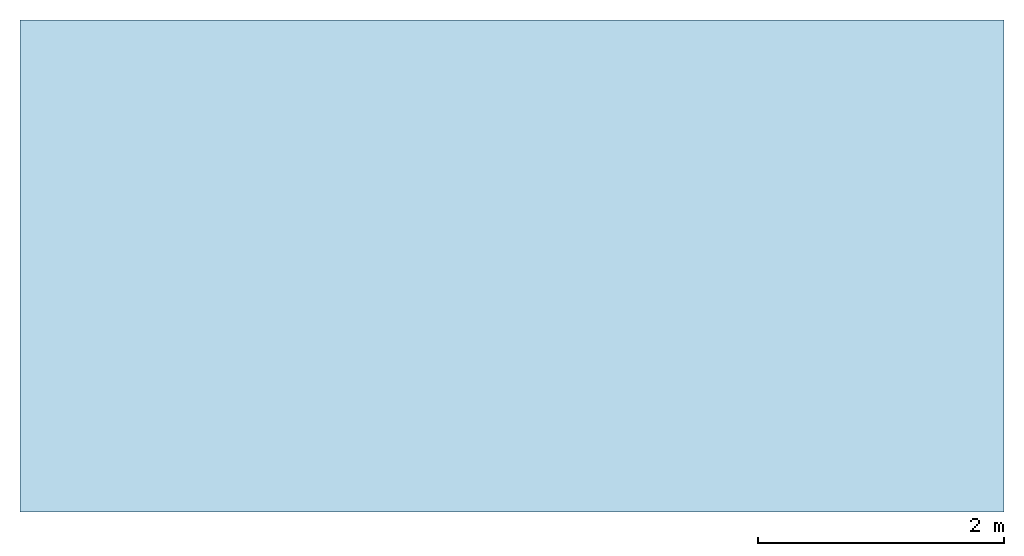
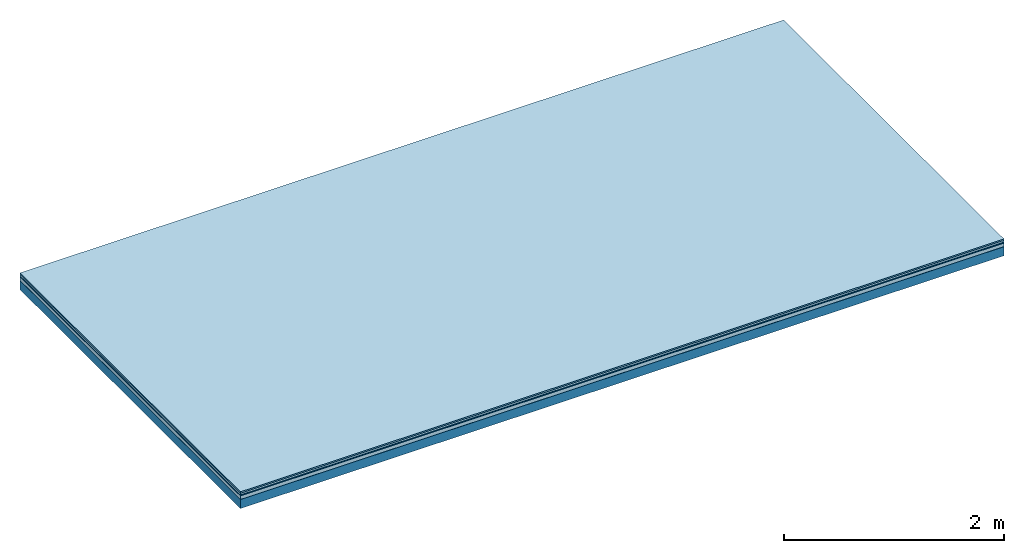
# One storey: 5 plates, 1 member, 1 element without a shape of its own.
"""IFC4 building model written with IfcOpenShell, lengths in metres."""

import ifcopenshell
import ifcopenshell.guid

model = None  # the IFC model being written
_history = None  # IfcOwnerHistory: only IFC2X3 demands one
_inside = {}  # id of a spatial element -> (the spatial element, [elements in it])
_under = {}  # id of a project, library or spatial element -> (it, [spatial elements below it])
_declared = {}  # id of a project -> (the project, [libraries it declares])
_typed = {}  # id of a type object -> (the type object, [elements of that type])
_made_of = {}  # id of a material, layer set ... -> (it, [elements and type objects made of it])


def new_model(schema):
    """Start an empty IFC model of exactly this schema.

    Asked for "IFC4X3", IfcOpenShell would pick the latest addendum, in which some entities
    have other attributes; the version numbers below select the first issue.
    IFC2X3 requires an IfcOwnerHistory on every rooted entity: one is made here for all.
    """
    global model, _history
    if schema == "IFC4X3":
        model = ifcopenshell.file(schema_version=(4, 3, 0, 0))
    else:
        model = ifcopenshell.file(schema=schema)
    _inside.clear()
    _under.clear()
    _declared.clear()
    _typed.clear()
    _made_of.clear()
    _history = None
    if model.schema == "IFC2X3":
        org = make("IfcOrganization", Name="unknown")
        user = make(
            "IfcPersonAndOrganization",
            ThePerson=make("IfcPerson", FamilyName="unknown"),
            TheOrganization=org,
        )
        app = make(
            "IfcApplication",
            ApplicationDeveloper=org,
            Version="unknown",
            ApplicationFullName="unknown",
            ApplicationIdentifier="unknown",
        )
        _history = make(
            "IfcOwnerHistory",
            OwningUser=user,
            OwningApplication=app,
            ChangeAction="ADDED",
            CreationDate=0,
        )
    return model


def make(cls, **values):
    """One entity of the class cls with the attributes given. An attribute that is None is left unset."""
    return model.create_entity(
        cls, **{name: value for name, value in values.items() if value is not None}
    )


def rooted(cls, **values):
    """An entity with a GlobalId (a new one), such as an element, a storey or a relation."""
    return make(cls, GlobalId=ifcopenshell.guid.new(), OwnerHistory=_history, **values)


def si_unit(unit_type, name, prefix=None):
    """IfcSIUnit, for example si_unit("LENGTHUNIT", "METRE", prefix="MILLI")."""
    return make("IfcSIUnit", UnitType=unit_type, Prefix=prefix, Name=name)


def derived_unit(unit_type, elements):
    """IfcDerivedUnit: a product of units, each with its exponent."""
    return make(
        "IfcDerivedUnit",
        Elements=[
            make("IfcDerivedUnitElement", Unit=unit, Exponent=power)
            for unit, power in elements
        ],
        UnitType=unit_type,
    )


def assignment(units):
    """IfcUnitAssignment: the units of a project."""
    return None if units is None else make("IfcUnitAssignment", Units=units)


def point(xyz):
    """IfcCartesianPoint."""
    return None if xyz is None else make("IfcCartesianPoint", Coordinates=xyz)


def direction(xyz):
    """IfcDirection."""
    return None if xyz is None else make("IfcDirection", DirectionRatios=xyz)


def frame(location, z_axis=None, x_axis=None):
    """IfcAxis2Placement3D, a coordinate frame: its origin and axes. An axis left out is left unset."""
    return make(
        "IfcAxis2Placement3D",
        Location=point(location),
        Axis=direction(z_axis),
        RefDirection=direction(x_axis),
    )


def frame_2d(location, x_axis=None):
    """IfcAxis2Placement2D, a coordinate frame in the plane: its origin and x axis."""
    return make(
        "IfcAxis2Placement2D", Location=point(location), RefDirection=direction(x_axis)
    )


def origin():
    """The frame at (0, 0, 0) with its axes left unset."""
    return frame((0.0, 0.0, 0.0))


def origin_with_axes():
    """The frame at (0, 0, 0) with the z axis (0, 0, 1) and the x axis (1, 0, 0) written out."""
    return frame((0.0, 0.0, 0.0), z_axis=(0.0, 0.0, 1.0), x_axis=(1.0, 0.0, 0.0))


def place(relative_to, where):
    """IfcLocalPlacement: puts the frame where relative to a parent placement (None: the world)."""
    return make(
        "IfcLocalPlacement", PlacementRelTo=relative_to, RelativePlacement=where
    )


def context(
    kind, dimensions, precision=None, world=None, true_north=None, identifier=None
):
    """IfcGeometricRepresentationContext, for example the 3D "Model" context."""
    return make(
        "IfcGeometricRepresentationContext",
        ContextIdentifier=identifier,
        ContextType=kind,
        CoordinateSpaceDimension=dimensions,
        Precision=precision,
        WorldCoordinateSystem=world,
        TrueNorth=true_north,
    )


def project(units=None, contexts=None):
    """IfcProject with its units and contexts."""
    return rooted(
        "IfcProject",
        Name="project",
        RepresentationContexts=contexts,
        UnitsInContext=assignment(units),
    )


def spatial(cls, under=None, at=None, **own):
    """A site, building, storey or space (cls), placed at a placement, below another one or the project."""
    s = rooted(cls, ObjectPlacement=at, **own)
    if under is not None:
        _under.setdefault(under.id(), (under, []))[1].append(s)
    return s


def profile(cls, at=None, kind="AREA", **sizes):
    """A parametric profile (cls). Its sizes go by their IFC names, for example OverallWidth=200.0."""
    return make(cls, ProfileType=kind, Position=at, **sizes)


def rectangle(**sizes):
    """IfcRectangleProfileDef."""
    return profile("IfcRectangleProfileDef", **sizes)


def extrude(swept, where, along, depth):
    """IfcExtrudedAreaSolid: the profile swept, set in the frame where, extruded along a direction by depth."""
    return make(
        "IfcExtrudedAreaSolid",
        SweptArea=swept,
        Position=where,
        ExtrudedDirection=direction(along),
        Depth=depth,
    )


def shape(context_of_items, identifier, shape_type, items):
    """IfcShapeRepresentation: the items that make up one representation, for example the "Body"."""
    return make(
        "IfcShapeRepresentation",
        ContextOfItems=context_of_items,
        RepresentationIdentifier=identifier,
        RepresentationType=shape_type,
        Items=items,
    )


def material(Name=None, Category=None):
    """IfcMaterial."""
    return make("IfcMaterial", Name=Name, Category=Category)


def layer(
    of_material, thickness, ventilated=None, Name=None, Category=None, Priority=None
):
    """IfcMaterialLayer: one layer of a wall or slab, of a material (None: an air gap)."""
    return make(
        "IfcMaterialLayer",
        Material=of_material,
        LayerThickness=thickness,
        IsVentilated=ventilated,
        Name=Name,
        Category=Category,
        Priority=Priority,
    )


def layer_set(layers, Name=None):
    """IfcMaterialLayerSet."""
    return make("IfcMaterialLayerSet", MaterialLayers=layers, LayerSetName=Name)


def made_of(thing, what):
    """Note that an element or type object is made of a material, layer set ...; save() writes the relation."""
    if what is not None:
        _made_of.setdefault(what.id(), (what, []))[1].append(thing)
    return thing


def type_object(cls, material=None, **own):
    """A type object (cls), such as IfcWallType, which elements share."""
    return made_of(rooted(cls, **own), material)


def element(
    cls,
    number,
    at=None,
    inside=None,
    cuts=None,
    type_object=None,
    material=None,
    context=None,
    identifier="Body",
    shape_type=None,
    held_by="IfcProductDefinitionShape",
    body=None,
    shapes=None,
    **own,
):
    """One element of the class cls, such as IfcWall. Its Tag is "e" and its number.

    at: its placement. inside: the storey or other place that contains it. cuts: it is an
    opening in that element (IfcRelVoidsElement). A single representation is given by context,
    identifier, shape_type and body (its items); several are given by shapes. held_by: the class
    of the entity that holds the representations. save() writes the other relations.
    """
    e = rooted(cls, Tag="e%d" % number, ObjectPlacement=at, **own)
    if body is not None:
        shapes = [shape(context, identifier, shape_type, body)]
    if shapes is not None:
        e.Representation = make(held_by, Representations=shapes)
    if inside is not None:
        _inside.setdefault(inside.id(), (inside, []))[1].append(e)
    if cuts is not None:
        rooted(
            "IfcRelVoidsElement", RelatingBuildingElement=cuts, RelatedOpeningElement=e
        )
    if type_object is not None:
        _typed.setdefault(type_object.id(), (type_object, []))[1].append(e)
    return made_of(e, material)


def aggregate(whole, parts):
    """IfcRelAggregates: a whole, such as a stair, and the parts it consists of."""
    return rooted("IfcRelAggregates", RelatingObject=whole, RelatedObjects=parts)


def save(model, path):
    """Write the relations noted so far, then the file.

    IfcRelAggregates (storeys below a building ...), IfcRelContainedInSpatialStructure (elements
    in a storey), IfcRelDefinesByType, IfcRelAssociatesMaterial and IfcRelDeclares: one each for
    every whole, place, type object, material and project.
    """
    for whole, parts in _under.values():
        aggregate(whole, parts)
    for where, things in _inside.values():
        rooted(
            "IfcRelContainedInSpatialStructure",
            RelatedElements=things,
            RelatingStructure=where,
        )
    for kind, things in _typed.values():
        rooted("IfcRelDefinesByType", RelatedObjects=things, RelatingType=kind)
    for what, things in _made_of.values():
        rooted("IfcRelAssociatesMaterial", RelatedObjects=things, RelatingMaterial=what)
    for by, libraries in _declared.values():
        rooted("IfcRelDeclares", RelatingContext=by, RelatedDefinitions=libraries)
    model.write(path)


model = new_model("IFC4")

# Units and contexts
plan_context = context("Plan", 3, precision=1e-05, world=origin(), true_north=direction((0.0, 1.0)))
model_context = context("Model", 3, precision=1e-05, world=origin(), true_north=direction((0.0, 1.0)))
ifc_project = project(units=[si_unit("LENGTHUNIT", "METRE"), derived_unit("SOUNDPRESSUREUNIT", [(si_unit("PRESSUREUNIT", "PASCAL", prefix="MICRO"), 0)]), si_unit("ENERGYUNIT", "JOULE", prefix="MEGA"), si_unit("MASSUNIT", "GRAM", prefix="KILO"), derived_unit("THERMALTRANSMITTANCEUNIT", [(si_unit("POWERUNIT", "WATT"), 1), (si_unit("AREAUNIT", "SQUARE_METRE"), -1), (si_unit("THERMODYNAMICTEMPERATUREUNIT", "KELVIN"), -1)]), derived_unit("AREADENSITYUNIT", [(si_unit("MASSUNIT", "GRAM", prefix="KILO"), 1), (si_unit("AREAUNIT", "SQUARE_METRE"), -1)]), derived_unit("USERDEFINED", [(si_unit("ENERGYUNIT", "JOULE", prefix="MEGA"), 1), (si_unit("AREAUNIT", "SQUARE_METRE"), -1)])], contexts=[plan_context, model_context])

# Site, building, storey
site = spatial("IfcSite", under=ifc_project)
building_placement = place(None, origin())
building = spatial("IfcBuilding", under=site, at=building_placement)
storey_placement = place(building_placement, origin())
storey = spatial("IfcBuildingStorey", under=building, at=storey_placement)

# Slab, member, plates
ifc_material_1 = material(Category="11.013")
ifc_layer_1 = layer(ifc_material_1, 0.015, Name="Flooring")
ifc_material_2 = material(Category="03.007")
ifc_layer_2 = layer(ifc_material_2, 0.02, Name="On-material")
ifc_material_3 = material(Name="Wood fiber generic product", Category="10.009")
ifc_layer_3 = layer(ifc_material_3, 0.01, Name="Impact sound insulation")
ifc_material_4 = material(Name="Cement panels, glued on sub-floor", Category="02.007")
ifc_layer_4 = layer(ifc_material_4, 0.04, Name="on Supporting structure")
ifc_material_5 = material(Name="protection", Category="09.007")
ifc_layer_5 = layer(ifc_material_5, 0.0005, Name="Sub-floor")
ifc_material_6 = material(Name="no composite action")
ifc_layer_6 = layer(ifc_material_6, 0.0, Name="Bond")
ifc_layer_7 = layer(None, 0.1, Name="Supporting structure")
ifc_layer_set = layer_set([ifc_layer_1, ifc_layer_2, ifc_layer_3, ifc_layer_4, ifc_layer_5, ifc_layer_6, ifc_layer_7])
slab_type = type_object("IfcSlabType", Name="A2059", PredefinedType="NOTDEFINED", material=ifc_layer_set)
slab_placement = place(None, frame((0.0, 0.0, 0.0), z_axis=(0.0, 0.0, -1.0), x_axis=(1.0, 0.0, 0.0)))
slab = element("IfcSlab", 1, at=slab_placement, inside=storey, type_object=slab_type, material=ifc_layer_set, Name="Slab #1")
ifc_material_7 = material(Name="Solid timber panel")
member_placement = place(slab_placement, origin())
member = element("IfcMember", 2, at=member_placement, material=ifc_material_7, Name="Supporting structure", context=plan_context, shape_type="SweptSolid", body=[
    extrude(rectangle(XDim=1.0, YDim=0.1, at=frame_2d((0.5, 0.05), x_axis=(1.0, 0.0))), frame((0.0, 4.0, 0.0855), z_axis=(0.0, -1.0, 0.0), x_axis=(1.0, 0.0, 0.0)), (0.0, 0.0, 1.0), 4.0),
    extrude(rectangle(XDim=1.0, YDim=0.1, at=frame_2d((0.5, 0.05), x_axis=(1.0, 0.0))), frame((1.0, 4.0, 0.0855), z_axis=(0.0, -1.0, 0.0), x_axis=(1.0, 0.0, 0.0)), (0.0, 0.0, 1.0), 4.0),
    extrude(rectangle(XDim=1.0, YDim=0.1, at=frame_2d((0.5, 0.05), x_axis=(1.0, 0.0))), frame((2.0, 4.0, 0.0855), z_axis=(0.0, -1.0, 0.0), x_axis=(1.0, 0.0, 0.0)), (0.0, 0.0, 1.0), 4.0),
    extrude(rectangle(XDim=1.0, YDim=0.1, at=frame_2d((0.5, 0.05), x_axis=(1.0, 0.0))), frame((3.0, 4.0, 0.0855), z_axis=(0.0, -1.0, 0.0), x_axis=(1.0, 0.0, 0.0)), (0.0, 0.0, 1.0), 4.0),
    extrude(rectangle(XDim=1.0, YDim=0.1, at=frame_2d((0.5, 0.05), x_axis=(1.0, 0.0))), frame((4.0, 4.0, 0.0855), z_axis=(0.0, -1.0, 0.0), x_axis=(1.0, 0.0, 0.0)), (0.0, 0.0, 1.0), 4.0),
    extrude(rectangle(XDim=1.0, YDim=0.1, at=frame_2d((0.5, 0.05), x_axis=(1.0, 0.0))), frame((5.0, 4.0, 0.0855), z_axis=(0.0, -1.0, 0.0), x_axis=(1.0, 0.0, 0.0)), (0.0, 0.0, 1.0), 4.0),
    extrude(rectangle(XDim=1.0, YDim=0.1, at=frame_2d((0.5, 0.05), x_axis=(1.0, 0.0))), frame((6.0, 4.0, 0.0855), z_axis=(0.0, -1.0, 0.0), x_axis=(1.0, 0.0, 0.0)), (0.0, 0.0, 1.0), 4.0),
    extrude(rectangle(XDim=1.0, YDim=0.1, at=frame_2d((0.5, 0.05), x_axis=(1.0, 0.0))), frame((7.0, 4.0, 0.0855), z_axis=(0.0, -1.0, 0.0), x_axis=(1.0, 0.0, 0.0)), (0.0, 0.0, 1.0), 4.0),
])
plate_1_placement = place(slab_placement, origin())
plate_1 = element("IfcPlate", 3, at=plate_1_placement, material=ifc_material_1, Name="Flooring", context=plan_context, shape_type="SweptSolid", body=[
    extrude(rectangle(XDim=8.0, YDim=4.0, at=frame_2d((4.0, 2.0), x_axis=(1.0, 0.0))), origin_with_axes(), (0.0, 0.0, 1.0), 0.015),
])
plate_2_placement = place(slab_placement, origin())
plate_2 = element("IfcPlate", 4, at=plate_2_placement, material=ifc_material_2, Name="On-material", context=plan_context, shape_type="SweptSolid", body=[
    extrude(rectangle(XDim=8.0, YDim=4.0, at=frame_2d((4.0, 2.0), x_axis=(1.0, 0.0))), frame((0.0, 0.0, 0.015), z_axis=(0.0, 0.0, 1.0), x_axis=(1.0, 0.0, 0.0)), (0.0, 0.0, 1.0), 0.02),
])
plate_3_placement = place(slab_placement, origin())
plate_3 = element("IfcPlate", 5, at=plate_3_placement, material=ifc_material_3, Name="Impact sound insulation", context=plan_context, shape_type="SweptSolid", body=[
    extrude(rectangle(XDim=8.0, YDim=4.0, at=frame_2d((4.0, 2.0), x_axis=(1.0, 0.0))), frame((0.0, 0.0, 0.035), z_axis=(0.0, 0.0, 1.0), x_axis=(1.0, 0.0, 0.0)), (0.0, 0.0, 1.0), 0.01),
])
plate_4_placement = place(slab_placement, origin())
plate_4 = element("IfcPlate", 6, at=plate_4_placement, material=ifc_material_4, Name="on Supporting structure", context=plan_context, shape_type="SweptSolid", body=[
    extrude(rectangle(XDim=8.0, YDim=4.0, at=frame_2d((4.0, 2.0), x_axis=(1.0, 0.0))), frame((0.0, 0.0, 0.045), z_axis=(0.0, 0.0, 1.0), x_axis=(1.0, 0.0, 0.0)), (0.0, 0.0, 1.0), 0.04),
])
plate_5_placement = place(slab_placement, origin())
plate_5 = element("IfcPlate", 7, at=plate_5_placement, material=ifc_material_5, Name="Sub-floor", context=plan_context, shape_type="SweptSolid", body=[
    extrude(rectangle(XDim=8.0, YDim=4.0, at=frame_2d((4.0, 2.0), x_axis=(1.0, 0.0))), frame((0.0, 0.0, 0.085), z_axis=(0.0, 0.0, 1.0), x_axis=(1.0, 0.0, 0.0)), (0.0, 0.0, 1.0), 0.0005),
])
aggregate(slab, [plate_1, plate_2, plate_3, plate_4, plate_5, member])

save(model, "model.ifc")
